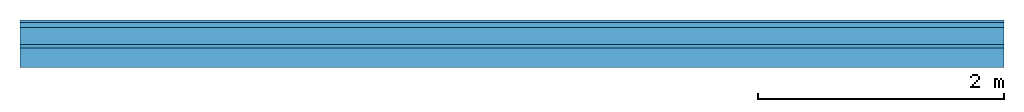
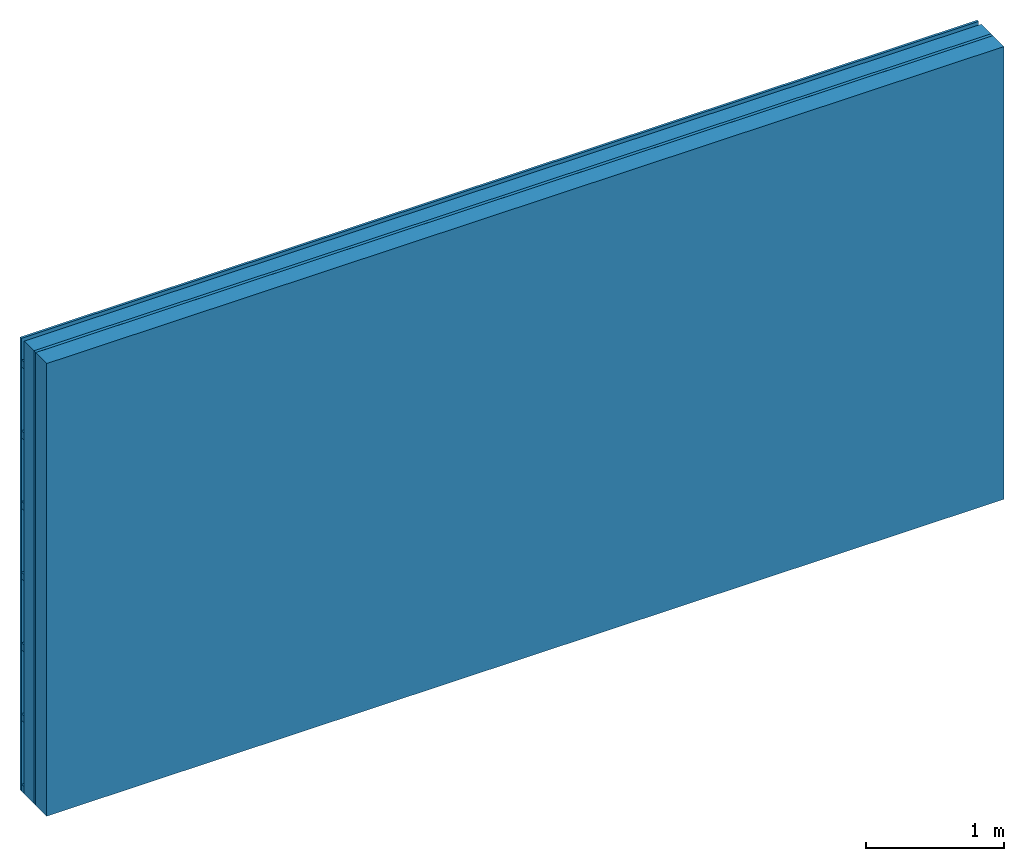
# One storey: 3 plates, 2 members, 1 element without a shape of its own.
"""IFC4 building model written with IfcOpenShell, lengths in metres."""

from ifc_helpers import new_model, si_unit, derived_unit, direction, frame, frame_2d, origin, origin_with_axes, place, context, project, spatial, rectangle, extrude, material, layer, layer_set, type_object, element, aggregate, save


model = new_model("IFC4")

# Units and contexts
plan_context = context("Plan", 3, precision=1e-05, world=origin(), true_north=direction((0.0, 1.0)))
model_context = context("Model", 3, precision=1e-05, world=origin(), true_north=direction((0.0, 1.0)))
ifc_project = project(units=[si_unit("LENGTHUNIT", "METRE"), derived_unit("SOUNDPRESSUREUNIT", [(si_unit("PRESSUREUNIT", "PASCAL", prefix="MICRO"), 0)]), si_unit("ENERGYUNIT", "JOULE", prefix="MEGA"), si_unit("MASSUNIT", "GRAM", prefix="KILO"), derived_unit("THERMALTRANSMITTANCEUNIT", [(si_unit("POWERUNIT", "WATT"), 1), (si_unit("AREAUNIT", "SQUARE_METRE"), -1), (si_unit("THERMODYNAMICTEMPERATUREUNIT", "KELVIN"), -1)]), derived_unit("AREADENSITYUNIT", [(si_unit("MASSUNIT", "GRAM", prefix="KILO"), 1), (si_unit("AREAUNIT", "SQUARE_METRE"), -1)]), derived_unit("USERDEFINED", [(si_unit("ENERGYUNIT", "JOULE", prefix="MEGA"), 1), (si_unit("AREAUNIT", "SQUARE_METRE"), -1)])], contexts=[plan_context, model_context])

# Site, building, storey
site = spatial("IfcSite", under=ifc_project)
building_placement = place(None, origin())
building = spatial("IfcBuilding", under=site, at=building_placement)
storey_placement = place(building_placement, origin())
storey = spatial("IfcBuildingStorey", under=building, at=storey_placement)

# Wall, members, plates
ifc_material_1 = material(Name="Wood cladding horizontal, closed")
ifc_layer_1 = layer(ifc_material_1, 0.02, Name="Cover 1st layer")
ifc_layer_2 = layer(None, 0.04, Name="Battens / profiles (ventilation)")
ifc_material_2 = material(Category="10.009")
ifc_layer_3 = layer(ifc_material_2, 0.14, Name="outside 2nd layer")
ifc_material_3 = material(Category="07.009")
ifc_layer_4 = layer(ifc_material_3, 0.027, Name="outside 1st layer")
ifc_material_4 = material(Name="Rigid, of the art")
ifc_layer_5 = layer(ifc_material_4, 0.0, Name="Bond")
ifc_layer_6 = layer(None, 0.16, Name="Support")
ifc_material_5 = material(Name="of the art")
ifc_layer_7 = layer(ifc_material_5, 0.0, Name="Bond")
ifc_layer_set = layer_set([ifc_layer_1, ifc_layer_2, ifc_layer_3, ifc_layer_4, ifc_layer_5, ifc_layer_6, ifc_layer_7])
wall_type = type_object("IfcWallType", Name="D1192", PredefinedType="NOTDEFINED", material=ifc_layer_set)
wall_placement = place(None, frame((0.0, 0.0, 0.0), z_axis=(0.0, -1.0, 0.0), x_axis=(1.0, 0.0, 0.0)))
wall = element("IfcWall", 1, at=wall_placement, inside=storey, type_object=wall_type, material=ifc_layer_set, Name="Wall #1")
ifc_material_6 = material()
member_1_placement = place(wall_placement, origin())
member_1 = element("IfcMember", 2, at=member_1_placement, material=ifc_material_6, Name="Battens / profiles (ventilation)", context=plan_context, shape_type="SweptSolid", body=[
    extrude(rectangle(XDim=0.06, YDim=0.04, at=frame_2d((0.03, 0.02), x_axis=(1.0, 0.0))), frame((0.0, 0.0, 0.02), z_axis=(1.0, 0.0, 0.0), x_axis=(0.0, 1.0, 0.0)), (0.0, 0.0, 1.0), 8.0),
    extrude(rectangle(XDim=0.06, YDim=0.04, at=frame_2d((0.03, 0.02), x_axis=(1.0, 0.0))), frame((0.0, 0.625, 0.02), z_axis=(1.0, 0.0, 0.0), x_axis=(0.0, 1.0, 0.0)), (0.0, 0.0, 1.0), 8.0),
    extrude(rectangle(XDim=0.06, YDim=0.04, at=frame_2d((0.03, 0.02), x_axis=(1.0, 0.0))), frame((0.0, 1.25, 0.02), z_axis=(1.0, 0.0, 0.0), x_axis=(0.0, 1.0, 0.0)), (0.0, 0.0, 1.0), 8.0),
    extrude(rectangle(XDim=0.06, YDim=0.04, at=frame_2d((0.03, 0.02), x_axis=(1.0, 0.0))), frame((0.0, 1.875, 0.02), z_axis=(1.0, 0.0, 0.0), x_axis=(0.0, 1.0, 0.0)), (0.0, 0.0, 1.0), 8.0),
    extrude(rectangle(XDim=0.06, YDim=0.04, at=frame_2d((0.03, 0.02), x_axis=(1.0, 0.0))), frame((0.0, 2.5, 0.02), z_axis=(1.0, 0.0, 0.0), x_axis=(0.0, 1.0, 0.0)), (0.0, 0.0, 1.0), 8.0),
    extrude(rectangle(XDim=0.06, YDim=0.04, at=frame_2d((0.03, 0.02), x_axis=(1.0, 0.0))), frame((0.0, 3.125, 0.02), z_axis=(1.0, 0.0, 0.0), x_axis=(0.0, 1.0, 0.0)), (0.0, 0.0, 1.0), 8.0),
    extrude(rectangle(XDim=0.06, YDim=0.04, at=frame_2d((0.03, 0.02), x_axis=(1.0, 0.0))), frame((0.0, 3.75, 0.02), z_axis=(1.0, 0.0, 0.0), x_axis=(0.0, 1.0, 0.0)), (0.0, 0.0, 1.0), 8.0),
])
ifc_material_7 = material(Name="Solid timber panel")
member_2_placement = place(wall_placement, origin())
member_2 = element("IfcMember", 3, at=member_2_placement, material=ifc_material_7, Name="Support", context=plan_context, shape_type="SweptSolid", body=[
    extrude(rectangle(XDim=1.0, YDim=0.16, at=frame_2d((0.5, 0.08), x_axis=(1.0, 0.0))), frame((0.0, 4.0, 0.227), z_axis=(0.0, -1.0, 0.0), x_axis=(1.0, 0.0, 0.0)), (0.0, 0.0, 1.0), 4.0),
    extrude(rectangle(XDim=1.0, YDim=0.16, at=frame_2d((0.5, 0.08), x_axis=(1.0, 0.0))), frame((1.0, 4.0, 0.227), z_axis=(0.0, -1.0, 0.0), x_axis=(1.0, 0.0, 0.0)), (0.0, 0.0, 1.0), 4.0),
    extrude(rectangle(XDim=1.0, YDim=0.16, at=frame_2d((0.5, 0.08), x_axis=(1.0, 0.0))), frame((2.0, 4.0, 0.227), z_axis=(0.0, -1.0, 0.0), x_axis=(1.0, 0.0, 0.0)), (0.0, 0.0, 1.0), 4.0),
    extrude(rectangle(XDim=1.0, YDim=0.16, at=frame_2d((0.5, 0.08), x_axis=(1.0, 0.0))), frame((3.0, 4.0, 0.227), z_axis=(0.0, -1.0, 0.0), x_axis=(1.0, 0.0, 0.0)), (0.0, 0.0, 1.0), 4.0),
    extrude(rectangle(XDim=1.0, YDim=0.16, at=frame_2d((0.5, 0.08), x_axis=(1.0, 0.0))), frame((4.0, 4.0, 0.227), z_axis=(0.0, -1.0, 0.0), x_axis=(1.0, 0.0, 0.0)), (0.0, 0.0, 1.0), 4.0),
    extrude(rectangle(XDim=1.0, YDim=0.16, at=frame_2d((0.5, 0.08), x_axis=(1.0, 0.0))), frame((5.0, 4.0, 0.227), z_axis=(0.0, -1.0, 0.0), x_axis=(1.0, 0.0, 0.0)), (0.0, 0.0, 1.0), 4.0),
    extrude(rectangle(XDim=1.0, YDim=0.16, at=frame_2d((0.5, 0.08), x_axis=(1.0, 0.0))), frame((6.0, 4.0, 0.227), z_axis=(0.0, -1.0, 0.0), x_axis=(1.0, 0.0, 0.0)), (0.0, 0.0, 1.0), 4.0),
    extrude(rectangle(XDim=1.0, YDim=0.16, at=frame_2d((0.5, 0.08), x_axis=(1.0, 0.0))), frame((7.0, 4.0, 0.227), z_axis=(0.0, -1.0, 0.0), x_axis=(1.0, 0.0, 0.0)), (0.0, 0.0, 1.0), 4.0),
])
plate_1_placement = place(wall_placement, origin())
plate_1 = element("IfcPlate", 4, at=plate_1_placement, material=ifc_material_1, Name="Cover 1st layer", context=plan_context, shape_type="SweptSolid", body=[
    extrude(rectangle(XDim=8.0, YDim=4.0, at=frame_2d((4.0, 2.0), x_axis=(1.0, 0.0))), origin_with_axes(), (0.0, 0.0, 1.0), 0.02),
])
plate_2_placement = place(wall_placement, origin())
plate_2 = element("IfcPlate", 5, at=plate_2_placement, material=ifc_material_2, Name="outside 2nd layer", context=plan_context, shape_type="SweptSolid", body=[
    extrude(rectangle(XDim=8.0, YDim=4.0, at=frame_2d((4.0, 2.0), x_axis=(1.0, 0.0))), frame((0.0, 0.0, 0.06), z_axis=(0.0, 0.0, 1.0), x_axis=(1.0, 0.0, 0.0)), (0.0, 0.0, 1.0), 0.14),
])
plate_3_placement = place(wall_placement, origin())
plate_3 = element("IfcPlate", 6, at=plate_3_placement, material=ifc_material_3, Name="outside 1st layer", context=plan_context, shape_type="SweptSolid", body=[
    extrude(rectangle(XDim=8.0, YDim=4.0, at=frame_2d((4.0, 2.0), x_axis=(1.0, 0.0))), frame((0.0, 0.0, 0.2), z_axis=(0.0, 0.0, 1.0), x_axis=(1.0, 0.0, 0.0)), (0.0, 0.0, 1.0), 0.027),
])
aggregate(wall, [plate_1, member_1, plate_2, plate_3, member_2])

save(model, "model.ifc")
